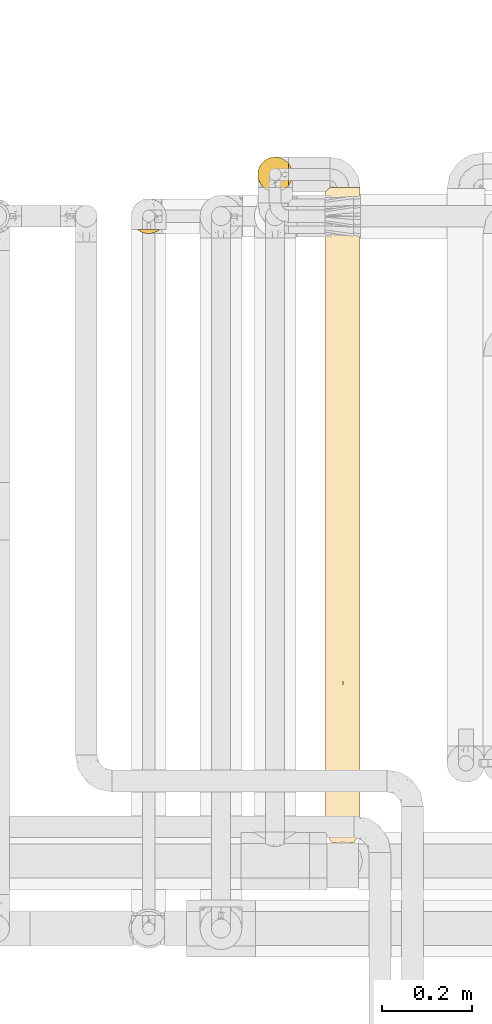
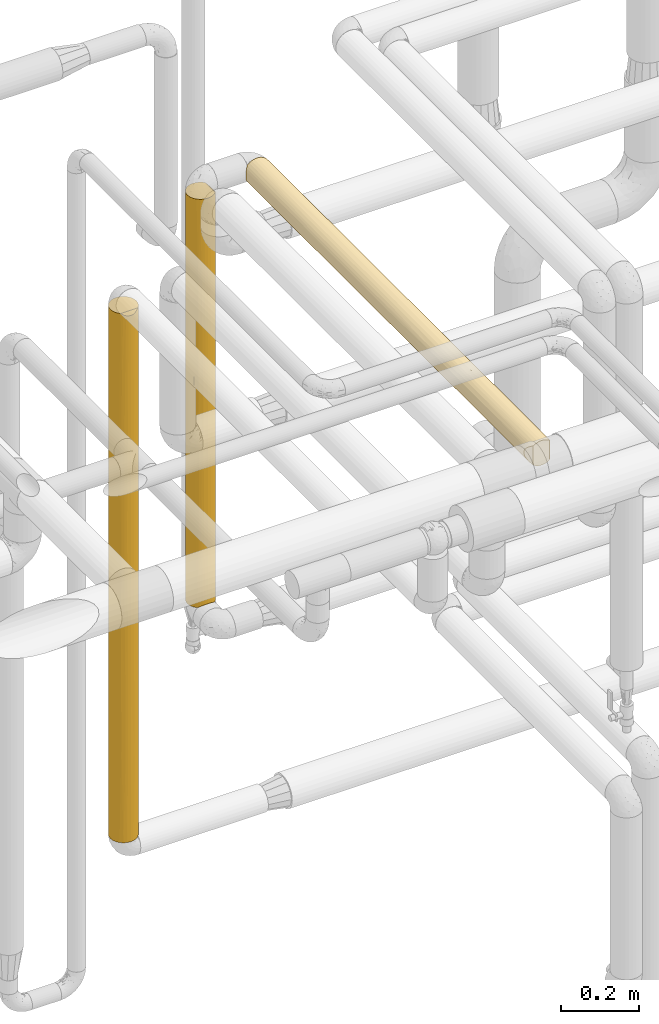
# One storey, part 46 of 827: 3 coverings.
"""IFC2X3 building model written with IfcOpenShell, lengths in millimetres."""

from ifc_helpers import new_model, entity, si_unit, converted_unit, derived_unit, direction, frame, origin, place, context, subcontext, project, spatial, faceted_brep, element, save


model = new_model("IFC2X3")

# Units and contexts
model_context = context("Model", 3, precision=0.01, world=origin(), true_north=direction((6.12303176911189e-17, 1.0)))
body_context = subcontext(model_context, "Body", "Model", "MODEL_VIEW")
ifc_project = project(units=[si_unit("LENGTHUNIT", "METRE", prefix="MILLI"), si_unit("AREAUNIT", "SQUARE_METRE"), si_unit("VOLUMEUNIT", "CUBIC_METRE"), converted_unit("PLANEANGLEUNIT", "DEGREE", entity("IfcRatioMeasure", 0.0174532925199433), si_unit("PLANEANGLEUNIT", "RADIAN"), dimensions=[0, 0, 0, 0, 0, 0, 0]), si_unit("MASSUNIT", "GRAM", prefix="KILO"), derived_unit("MASSDENSITYUNIT", [(si_unit("MASSUNIT", "GRAM", prefix="KILO"), 1), (si_unit("LENGTHUNIT", "METRE"), -3)]), derived_unit("MOMENTOFINERTIAUNIT", [(si_unit("LENGTHUNIT", "METRE"), 4)]), si_unit("TIMEUNIT", "SECOND"), si_unit("FREQUENCYUNIT", "HERTZ"), si_unit("THERMODYNAMICTEMPERATUREUNIT", "DEGREE_CELSIUS"), derived_unit("THERMALTRANSMITTANCEUNIT", [(si_unit("MASSUNIT", "GRAM", prefix="KILO"), 1), (si_unit("THERMODYNAMICTEMPERATUREUNIT", "KELVIN"), -1), (si_unit("TIMEUNIT", "SECOND"), -3)]), derived_unit("VOLUMETRICFLOWRATEUNIT", [(si_unit("LENGTHUNIT", "METRE"), 3), (si_unit("TIMEUNIT", "SECOND"), -1)]), derived_unit("MASSFLOWRATEUNIT", [(si_unit("MASSUNIT", "GRAM", prefix="KILO"), 1), (si_unit("TIMEUNIT", "SECOND"), -1)]), derived_unit("ROTATIONALFREQUENCYUNIT", [(si_unit("TIMEUNIT", "SECOND"), -1)]), si_unit("ELECTRICCURRENTUNIT", "AMPERE"), si_unit("ELECTRICVOLTAGEUNIT", "VOLT"), si_unit("POWERUNIT", "WATT"), si_unit("FORCEUNIT", "NEWTON", prefix="KILO"), si_unit("ILLUMINANCEUNIT", "LUX"), si_unit("LUMINOUSFLUXUNIT", "LUMEN"), si_unit("LUMINOUSINTENSITYUNIT", "CANDELA"), derived_unit("USERDEFINED", [(si_unit("MASSUNIT", "GRAM", prefix="KILO"), -1), (si_unit("LENGTHUNIT", "METRE"), -2), (si_unit("TIMEUNIT", "SECOND"), 3), (si_unit("LUMINOUSFLUXUNIT", "LUMEN"), 1)]), derived_unit("LINEARVELOCITYUNIT", [(si_unit("LENGTHUNIT", "METRE"), 1), (si_unit("TIMEUNIT", "SECOND"), -1)]), si_unit("PRESSUREUNIT", "PASCAL"), derived_unit("USERDEFINED", [(si_unit("LENGTHUNIT", "METRE"), -2), (si_unit("MASSUNIT", "GRAM", prefix="KILO"), 1), (si_unit("TIMEUNIT", "SECOND"), -2)]), derived_unit("LINEARFORCEUNIT", [(si_unit("MASSUNIT", "GRAM", prefix="KILO"), 1), (si_unit("LENGTHUNIT", "METRE"), 1), (si_unit("TIMEUNIT", "SECOND"), -2), (si_unit("LENGTHUNIT", "METRE"), -1)]), derived_unit("PLANARFORCEUNIT", [(si_unit("MASSUNIT", "GRAM", prefix="KILO"), 1), (si_unit("LENGTHUNIT", "METRE"), 1), (si_unit("TIMEUNIT", "SECOND"), -2), (si_unit("LENGTHUNIT", "METRE"), -2)])], contexts=[model_context])

# Site, building, storey
site_placement = place(None, origin())
site = spatial("IfcSite", under=ifc_project, at=site_placement, CompositionType="ELEMENT")
building_placement = place(site_placement, origin())
building = spatial("IfcBuilding", under=site, at=building_placement, CompositionType="ELEMENT")
storey_placement = place(building_placement, frame((0.0, 0.0, 28200.0)))
storey = spatial("IfcBuildingStorey", under=building, at=storey_placement, Name="08", CompositionType="ELEMENT", Elevation=28200.0)

# Coverings
covering_1_placement = place(storey_placement, frame((54299.79, 16110.78, 2660.04)))
element("IfcCovering", 1, at=covering_1_placement, inside=storey, Name=":ADSK_", ObjectType=":ADSK_", PredefinedType="INSULATION", context=body_context, shape_type="Brep", body=[
    faceted_brep([(23.02, 1.6, 5.55), (31.28, 1.6, 2.6), (40.0, 1.6, 1.6), (48.72, 1.6, 2.6), (56.97, 1.6, 5.55), (64.34, 1.6, 10.3), (64.34, 1.6, 69.69), (56.97, 1.6, 74.44), (48.72, 1.6, 77.39), (40.0, 1.6, 78.4), (31.28, 1.6, 77.39), (23.02, 1.6, 74.44), (15.65, 1.6, 69.69), (15.65, 1.6, 10.3), (59.2, 1452.5, 6.74), (49.93, 1452.5, 2.9), (40.0, 1452.5, 1.6), (31.8, 1452.5, 2.48), (23.99, 1452.5, 5.09), (16.92, 1452.5, 9.3), (10.91, 1452.5, 14.92), (10.88, 1452.5, 65.03), (16.89, 1452.5, 70.67), (23.97, 1452.5, 74.89), (31.79, 1452.5, 77.51), (40.0, 1452.5, 78.4), (49.93, 1452.5, 77.09), (59.2, 1452.5, 73.25), (67.15, 1452.5, 67.15), (73.25, 1452.5, 59.2), (77.09, 1452.5, 49.93), (78.4, 1452.5, 40.0), (77.09, 1452.5, 30.06), (73.25, 1452.5, 20.8), (67.15, 1452.5, 12.84), (2.98, 1173.83, 29.79), (2.2, 1443.8, 33.2), (4.0, 1445.59, 26.62), (6.08, 1209.09, 21.99), (5.44, 967.77, 23.25), (10.46, 1249.57, 15.46), (13.77, 1100.45, 11.95), (8.91, 1058.93, 17.44), (27.83, 1248.12, 3.57), (8.85, 810.39, 17.53), (11.55, 8.32, 14.2), (13.88, 340.69, 11.84), (2.57, 925.73, 31.39), (20.76, 1129.93, 6.76), (27.06, 442.82, 3.84), (27.06, 204.04, 3.84), (19.54, 214.27, 7.5), (2.94, 653.44, 29.93), (1.6, 457.43, 40.0), (1.6, 673.8, 40.0), (2.01, 24.0, 34.36), (1.6, 241.05, 40.0), (2.56, 303.36, 31.46), (6.8, 450.98, 20.69), (6.69, 226.01, 20.88), (8.07, 14.04, 18.65), (5.29, 18.62, 23.57), (1.6, 1226.82, 40.0), (1.6, 1443.2, 40.0), (40.0, 727.05, 1.6), (40.0, 545.68, 1.6), (40.0, 364.32, 1.6), (14.71, 534.08, 11.1), (20.63, 602.44, 6.84), (18.94, 412.01, 7.88), (40.0, 1089.77, 1.6), (40.0, 908.41, 1.6), (27.83, 1011.74, 3.57), (1.6, 890.17, 40.0), (20.81, 862.12, 6.73), (28.86, 725.52, 3.24), (3.25, 21.96, 28.84), (14.29, 729.46, 11.47), (6.93, 1448.52, 20.46), (5.21, 753.17, 23.72), (1.6, 24.68, 40.0), (65.7, 727.26, 11.47), (71.28, 881.11, 17.73), (70.83, 648.43, 17.11), (77.61, 1141.87, 32.29), (77.56, 909.84, 32.03), (75.47, 1022.08, 25.3), (63.37, 1158.85, 9.53), (59.53, 822.55, 6.93), (59.75, 581.75, 7.07), (48.39, 1185.88, 2.52), (54.69, 1006.28, 4.52), (46.7, 928.56, 2.19), (70.46, 1198.49, 16.62), (66.11, 340.49, 11.84), (59.46, 323.48, 6.9), (52.93, 204.08, 3.84), (51.95, 730.09, 3.5), (77.98, 24.0, 34.36), (78.4, 241.05, 40.0), (78.4, 24.68, 40.0), (73.3, 225.55, 20.88), (73.19, 450.09, 20.69), (64.72, 944.28, 10.61), (75.47, 1261.66, 25.3), (52.93, 442.89, 3.84), (76.74, 21.96, 28.84), (74.7, 18.62, 23.57), (55.96, 1239.91, 5.07), (77.05, 653.93, 29.92), (77.43, 303.36, 31.46), (71.92, 14.04, 18.65), (78.4, 457.43, 40.0), (68.44, 8.32, 14.2), (78.4, 890.17, 40.0), (67.1, 535.84, 12.8), (74.52, 746.35, 23.18), (78.4, 673.8, 40.0), (78.4, 1236.12, 40.0), (75.47, 1261.66, 54.69), (67.84, 969.35, 66.44), (65.7, 727.26, 68.52), (72.51, 754.88, 60.42), (77.61, 1141.87, 47.7), (48.48, 821.3, 77.45), (52.93, 442.89, 76.15), (56.41, 716.73, 74.71), (70.46, 1198.49, 63.37), (63.37, 1158.85, 70.46), (77.05, 653.93, 50.08), (75.47, 1022.08, 54.69), (46.72, 1231.25, 77.8), (40.0, 1089.77, 78.4), (66.11, 340.49, 68.15), (68.44, 8.32, 65.79), (73.3, 225.55, 59.11), (54.69, 1252.9, 75.47), (77.98, 24.0, 45.63), (77.43, 303.36, 48.53), (76.74, 21.96, 51.15), (71.92, 14.04, 61.34), (52.93, 204.08, 76.15), (40.0, 364.32, 78.4), (73.19, 450.09, 59.3), (60.45, 214.24, 72.49), (60.33, 451.94, 72.57), (74.7, 18.62, 56.42), (65.28, 532.86, 68.9), (54.69, 1006.28, 75.47), (40.0, 727.04, 78.4), (40.0, 545.68, 78.4), (77.56, 909.84, 47.96), (61.58, 917.33, 71.75), (72.16, 1011.5, 60.97), (46.8, 1023.31, 77.79), (27.81, 1248.05, 76.41), (6.91, 1448.53, 59.5), (6.07, 1208.66, 57.99), (10.42, 1249.33, 64.48), (20.63, 602.57, 73.15), (13.88, 340.69, 68.15), (20.53, 323.43, 73.1), (27.06, 442.82, 76.15), (27.06, 204.04, 76.15), (28.84, 725.46, 76.74), (27.81, 1011.5, 76.41), (20.8, 862.25, 73.25), (20.73, 1129.77, 73.21), (2.57, 926.1, 48.58), (2.94, 653.46, 50.07), (13.73, 1100.41, 68.01), (8.84, 809.04, 62.44), (14.29, 729.39, 68.52), (2.01, 24.0, 45.63), (11.09, 540.13, 65.28), (6.8, 450.95, 59.3), (6.69, 226.0, 59.11), (8.9, 1058.04, 62.52), (2.97, 1173.7, 50.18), (3.99, 1445.6, 53.35), (2.2, 1443.8, 46.78), (5.42, 967.2, 56.71), (3.25, 21.96, 51.15), (2.56, 303.36, 48.53), (5.29, 18.62, 56.42), (11.55, 8.32, 65.79), (8.07, 14.04, 61.34), (5.2, 753.19, 56.25)], [[[0, 1, 2, 3, 4, 5, 6, 7, 8, 9, 10, 11, 12, 13]], [[14, 15, 16, 17, 18, 19, 20, 21, 22, 23, 24, 25, 26, 27, 28, 29, 30, 31, 32, 33, 34]], [[35, 36, 37]], [[35, 38, 39]], [[40, 41, 42]], [[43, 18, 17]], [[39, 42, 44]], [[38, 42, 39]], [[13, 45, 46]], [[35, 39, 47]], [[18, 48, 19]], [[49, 50, 51]], [[52, 53, 54]], [[55, 56, 57]], [[52, 58, 57]], [[46, 45, 59]], [[59, 60, 61]], [[62, 63, 36]], [[19, 41, 40]], [[18, 43, 48]], [[49, 64, 65, 66, 50]], [[67, 68, 69]], [[57, 58, 59]], [[70, 17, 16]], [[1, 50, 66]], [[70, 71, 72, 43]], [[62, 47, 54, 73]], [[60, 59, 45]], [[51, 13, 46]], [[0, 50, 1]], [[41, 48, 74]], [[75, 49, 68]], [[59, 76, 57]], [[77, 41, 74]], [[52, 57, 53]], [[55, 57, 76]], [[44, 42, 41]], [[67, 58, 44]], [[78, 38, 37]], [[35, 47, 62]], [[62, 36, 35]], [[59, 61, 76]], [[46, 59, 58]], [[44, 79, 39]], [[70, 43, 17]], [[2, 1, 66]], [[48, 43, 72]], [[48, 72, 74]], [[19, 48, 41]], [[75, 74, 72]], [[68, 77, 74]], [[67, 69, 46]], [[64, 49, 75]], [[75, 68, 74]], [[49, 51, 69]], [[51, 50, 0]], [[13, 51, 0]], [[51, 46, 69]], [[79, 47, 39]], [[47, 52, 54]], [[37, 38, 35]], [[78, 20, 40]], [[38, 78, 40]], [[44, 41, 77]], [[67, 44, 77]], [[79, 58, 52]], [[38, 40, 42]], [[19, 40, 20]], [[58, 79, 44]], [[47, 79, 52]], [[71, 75, 72]], [[71, 64, 75]], [[49, 69, 68]], [[58, 67, 46]], [[68, 67, 77]], [[56, 55, 80]], [[56, 53, 57]], [[81, 82, 83]], [[84, 85, 86]], [[14, 34, 87]], [[88, 81, 89]], [[90, 91, 92]], [[34, 93, 87]], [[89, 94, 95]], [[95, 4, 96]], [[95, 5, 4]], [[97, 92, 91]], [[2, 66, 3]], [[98, 99, 100]], [[101, 94, 102]], [[88, 103, 81]], [[86, 104, 84]], [[66, 65, 105, 96]], [[101, 106, 107]], [[90, 108, 91]], [[109, 110, 102]], [[106, 101, 110]], [[107, 111, 101]], [[112, 110, 109]], [[3, 96, 4]], [[110, 98, 106]], [[94, 101, 113]], [[91, 108, 87]], [[113, 5, 94]], [[114, 85, 84]], [[110, 99, 98]], [[104, 33, 32]], [[91, 88, 97]], [[83, 115, 81]], [[101, 111, 113]], [[110, 101, 102]], [[83, 116, 102]], [[85, 117, 109]], [[34, 33, 93]], [[103, 88, 91]], [[32, 31, 118]], [[15, 90, 16]], [[104, 93, 33]], [[103, 82, 81]], [[66, 96, 3]], [[95, 96, 105]], [[89, 95, 105]], [[95, 94, 5]], [[89, 105, 97]], [[89, 81, 115]], [[116, 83, 82]], [[92, 64, 71, 70]], [[97, 88, 89]], [[103, 91, 87]], [[87, 93, 103]], [[82, 93, 86]], [[93, 82, 103]], [[85, 116, 86]], [[64, 92, 97]], [[90, 92, 70]], [[16, 90, 70]], [[108, 15, 14]], [[15, 108, 90]], [[87, 108, 14]], [[84, 32, 118]], [[93, 104, 86]], [[32, 84, 104]], [[114, 84, 118]], [[116, 85, 109]], [[65, 97, 105]], [[65, 64, 97]], [[115, 102, 94]], [[86, 116, 82]], [[102, 116, 109]], [[102, 115, 83]], [[89, 115, 94]], [[110, 112, 99]], [[117, 85, 114]], [[117, 112, 109]], [[119, 30, 29]], [[120, 121, 122]], [[30, 119, 123]], [[124, 125, 126]], [[127, 28, 128]], [[29, 28, 127]], [[30, 118, 31]], [[122, 129, 130]], [[131, 25, 132]], [[133, 134, 135]], [[128, 27, 136]], [[137, 99, 138]], [[138, 139, 137]], [[129, 112, 117]], [[140, 135, 134]], [[8, 141, 142]], [[135, 139, 138]], [[138, 143, 135]], [[125, 144, 145]], [[125, 141, 144]], [[27, 26, 136]], [[135, 140, 146]], [[144, 6, 133]], [[28, 27, 128]], [[125, 145, 126]], [[147, 143, 122]], [[141, 8, 7]], [[143, 138, 129]], [[129, 138, 112]], [[6, 134, 133]], [[148, 136, 131]], [[125, 149, 150, 142, 141]], [[135, 146, 139]], [[133, 135, 143]], [[151, 117, 114]], [[151, 114, 123]], [[121, 120, 152]], [[9, 8, 142]], [[120, 153, 127]], [[120, 127, 128]], [[154, 149, 124]], [[118, 123, 114]], [[127, 153, 119]], [[144, 141, 7]], [[6, 144, 7]], [[144, 133, 145]], [[133, 147, 145]], [[121, 152, 126]], [[126, 145, 147]], [[124, 126, 148]], [[148, 131, 154]], [[125, 124, 149]], [[152, 128, 148]], [[147, 122, 121]], [[129, 122, 143]], [[153, 122, 130]], [[128, 152, 120]], [[126, 152, 148]], [[131, 136, 26]], [[128, 136, 148]], [[25, 131, 26]], [[131, 132, 154]], [[149, 154, 132]], [[148, 154, 124]], [[127, 119, 29]], [[123, 119, 130]], [[123, 130, 151]], [[30, 123, 118]], [[130, 129, 151]], [[151, 129, 117]], [[143, 147, 133]], [[126, 147, 121]], [[122, 153, 120]], [[119, 153, 130]], [[99, 137, 100]], [[99, 112, 138]], [[155, 132, 24]], [[156, 157, 158]], [[159, 160, 161]], [[142, 150, 162, 163]], [[164, 165, 166]], [[155, 167, 165]], [[168, 54, 169]], [[155, 24, 23]], [[9, 142, 10]], [[170, 171, 172]], [[173, 56, 80]], [[174, 175, 160]], [[160, 175, 176]], [[161, 12, 11]], [[157, 177, 158]], [[166, 167, 170]], [[62, 168, 178]], [[179, 180, 178]], [[157, 178, 181]], [[165, 149, 132, 155]], [[182, 176, 183]], [[11, 163, 161]], [[176, 182, 184]], [[160, 176, 185]], [[183, 169, 53]], [[160, 185, 12]], [[10, 163, 11]], [[173, 183, 56]], [[186, 176, 184]], [[158, 22, 21]], [[171, 170, 177]], [[178, 157, 179]], [[165, 167, 166]], [[183, 173, 182]], [[169, 183, 175]], [[22, 170, 167]], [[180, 63, 62]], [[180, 62, 178]], [[168, 62, 73, 54]], [[176, 186, 185]], [[183, 176, 175]], [[187, 175, 171]], [[25, 24, 132]], [[168, 181, 178]], [[23, 22, 167]], [[167, 155, 23]], [[166, 170, 172]], [[172, 159, 166]], [[166, 159, 164]], [[159, 174, 160]], [[149, 165, 164]], [[159, 172, 174]], [[164, 159, 162]], [[142, 163, 10]], [[161, 163, 162]], [[159, 161, 162]], [[161, 160, 12]], [[187, 168, 169]], [[177, 157, 181]], [[179, 157, 156]], [[177, 181, 171]], [[158, 177, 170]], [[187, 171, 181]], [[174, 171, 175]], [[22, 158, 170]], [[158, 21, 156]], [[168, 187, 181]], [[175, 187, 169]], [[150, 164, 162]], [[150, 149, 164]], [[171, 174, 172]], [[183, 53, 56]], [[54, 53, 169]], [[134, 6, 5, 113, 111, 107, 106, 98, 100, 137, 139, 146, 140]], [[173, 80, 55, 76, 61, 60, 45, 13, 12, 185, 186, 184, 182]], [[36, 63, 180, 179, 156, 21, 20, 78, 37]]]),
])
covering_2_placement = place(storey_placement, frame((54149.79, 17552.38, 1397.5)))
element("IfcCovering", 2, at=covering_2_placement, inside=storey, Name=":ADSK_", ObjectType=":ADSK_", PredefinedType="INSULATION", context=body_context, shape_type="Brep", body=[
    faceted_brep([(56.01, 5.09, 1273.4), (63.08, 9.31, 1273.4), (69.1, 14.94, 1273.4), (69.1, 65.05, 1273.4), (63.08, 70.68, 1273.4), (56.01, 74.9, 1273.4), (48.2, 77.51, 1273.4), (40.0, 78.4, 1273.4), (30.06, 77.09, 1273.4), (20.8, 73.25, 1273.4), (12.84, 67.15, 1273.4), (6.74, 59.2, 1273.4), (2.9, 49.93, 1273.4), (1.6, 40.0, 1273.4), (2.9, 30.06, 1273.4), (6.74, 20.8, 1273.4), (12.84, 12.84, 1273.4), (20.8, 6.74, 1273.4), (30.06, 2.9, 1273.4), (40.0, 1.6, 1273.4), (48.2, 2.48, 1273.4), (77.09, 49.93, 1.6), (78.4, 40.0, 1.6), (77.51, 31.79, 1.6), (74.9, 23.98, 1.6), (70.68, 16.91, 1.6), (65.05, 10.9, 1.6), (14.94, 10.9, 1.6), (9.31, 16.91, 1.6), (5.09, 23.98, 1.6), (2.48, 31.79, 1.6), (1.6, 40.0, 1.6), (2.9, 49.93, 1.6), (6.74, 59.2, 1.6), (12.84, 67.15, 1.6), (20.8, 73.25, 1.6), (30.06, 77.09, 1.6), (40.0, 78.4, 1.6), (49.93, 77.09, 1.6), (59.2, 73.25, 1.6), (67.15, 67.15, 1.6), (73.25, 59.2, 1.6), (59.51, 6.92, 5.57), (62.54, 8.91, 299.92), (76.41, 27.82, 357.21), (70.45, 16.6, 321.3), (77.02, 29.8, 1005.37), (74.47, 23.08, 1069.54), (76.5, 28.07, 732.1), (47.71, 2.38, 671.05), (56.75, 5.44, 544.14), (59.66, 7.01, 912.24), (50.2, 2.98, 305.85), (56.59, 5.37, 205.09), (40.0, 1.6, 227.27), (46.78, 2.2, 10.29), (53.36, 4.0, 8.5), (65.76, 11.52, 1049.24), (66.56, 12.27, 805.85), (40.0, 1.6, 1057.02), (50.05, 2.93, 966.7), (70.94, 17.26, 640.31), (73.07, 20.48, 1269.42), (71.08, 17.45, 963.52), (40.0, 1.6, 957.78), (40.0, 1.6, 876.39), (78.4, 40.0, 632.85), (78.4, 40.0, 831.35), (40.0, 1.6, 10.9), (78.4, 40.0, 317.22), (64.71, 10.6, 562.87), (77.79, 33.21, 1264.7), (76.0, 26.63, 1266.5), (78.4, 40.0, 1047.72), (78.4, 40.0, 1264.1), (40.0, 1.6, 660.01), (40.0, 1.6, 642.15), (40.0, 1.6, 443.64), (78.4, 40.0, 217.97), (78.4, 40.0, 398.6), (78.4, 40.0, 614.98), (63.37, 70.46, 282.77), (70.46, 63.37, 254.12), (61.81, 71.6, 549.57), (65.92, 68.32, 733.64), (70.94, 62.73, 634.54), (77.7, 47.26, 308.29), (73.07, 59.51, 1269.42), (71.29, 62.25, 1059.46), (74.59, 56.66, 925.92), (75.47, 54.69, 357.63), (77.52, 48.15, 939.54), (77.49, 48.3, 616.5), (53.64, 75.89, 191.55), (71.08, 62.54, 847.06), (76.0, 53.36, 1266.5), (47.5, 77.65, 312.94), (40.0, 78.4, 624.28), (50.65, 76.89, 692.04), (54.69, 75.47, 409.71), (40.0, 78.4, 217.97), (40.0, 78.4, 407.9), (77.79, 46.78, 1264.7), (66.24, 68.03, 996.73), (52.17, 76.41, 996.74), (40.0, 78.4, 1057.02), (59.66, 72.98, 1058.41), (59.66, 72.98, 812.0), (74.94, 55.9, 587.7), (40.0, 78.4, 840.65), (16.62, 70.46, 260.79), (9.53, 63.37, 325.87), (32.89, 77.73, 948.84), (31.63, 77.47, 628.43), (25.3, 75.47, 905.95), (25.3, 75.47, 369.04), (32.73, 77.7, 312.94), (1.6, 40.0, 217.97), (1.6, 40.0, 1070.24), (23.73, 74.78, 606.15), (2.3, 47.31, 952.13), (4.52, 54.69, 246.65), (9.28, 63.04, 615.91), (4.52, 54.69, 531.31), (2.29, 47.28, 326.15), (9.53, 63.37, 905.95), (4.52, 54.69, 1004.02), (16.62, 70.46, 1004.02), (16.62, 70.46, 637.5), (2.22, 46.88, 563.24), (3.47, 51.84, 767.67), (1.6, 40.0, 434.34), (1.6, 40.0, 650.71), (1.6, 40.0, 867.09), (1.6, 40.0, 1057.02), (3.1, 29.34, 582.95), (3.58, 27.82, 278.25), (7.01, 20.33, 462.99), (17.26, 9.05, 640.45), (23.65, 5.25, 374.73), (28.04, 3.5, 542.89), (9.53, 16.62, 992.22), (2.34, 32.49, 962.05), (4.1, 26.35, 1083.44), (6.59, 21.05, 248.52), (10.84, 15.01, 282.23), (4.52, 25.3, 865.28), (8.39, 18.18, 725.42), (17.44, 8.91, 314.42), (11.67, 14.07, 541.35), (29.8, 2.97, 269.71), (26.63, 4.0, 8.5), (20.48, 6.92, 5.57), (32.94, 2.25, 799.96), (16.62, 9.53, 1020.87), (33.21, 2.2, 10.29), (25.3, 4.52, 917.65), (32.18, 2.4, 1040.19)], [[[0, 1, 2, 3, 4, 5, 6, 7, 8, 9, 10, 11, 12, 13, 14, 15, 16, 17, 18, 19, 20]], [[21, 22, 23, 24, 25, 26, 27, 28, 29, 30, 31, 32, 33, 34, 35, 36, 37, 38, 39, 40, 41]], [[42, 26, 43]], [[24, 23, 44]], [[43, 26, 45]], [[46, 47, 48]], [[49, 50, 51]], [[50, 52, 53]], [[54, 55, 52]], [[52, 56, 53]], [[57, 51, 58]], [[59, 60, 20]], [[44, 61, 45]], [[62, 63, 47]], [[60, 59, 64, 65]], [[66, 67, 48]], [[60, 49, 51]], [[54, 68, 55]], [[23, 69, 44]], [[50, 70, 51]], [[70, 61, 58]], [[70, 50, 43]], [[20, 60, 0]], [[46, 71, 72]], [[56, 52, 55]], [[62, 2, 63]], [[53, 42, 43]], [[48, 44, 66]], [[73, 71, 46]], [[45, 24, 44]], [[73, 74, 71]], [[48, 63, 61]], [[45, 26, 25]], [[1, 0, 51]], [[49, 52, 50]], [[57, 2, 1]], [[48, 47, 63]], [[61, 44, 48]], [[72, 62, 47]], [[67, 46, 48]], [[20, 19, 59]], [[60, 65, 49]], [[60, 51, 0]], [[49, 65, 75, 76, 77]], [[52, 49, 77]], [[45, 70, 43]], [[61, 63, 58]], [[57, 58, 63]], [[51, 70, 58]], [[2, 57, 63]], [[51, 57, 1]], [[45, 25, 24]], [[70, 45, 61]], [[42, 53, 56]], [[50, 53, 43]], [[52, 77, 54]], [[23, 22, 78, 69]], [[44, 69, 79, 80, 66]], [[72, 47, 46]], [[46, 67, 73]], [[40, 81, 82]], [[83, 84, 85]], [[86, 79, 69, 78]], [[21, 78, 22]], [[3, 87, 88]], [[87, 89, 88]], [[41, 90, 21]], [[89, 91, 92]], [[93, 81, 39]], [[91, 73, 67]], [[41, 40, 82]], [[88, 89, 94]], [[95, 89, 87]], [[96, 93, 38]], [[96, 97, 98]], [[99, 83, 81]], [[86, 92, 79]], [[96, 100, 101, 97]], [[73, 91, 102]], [[3, 103, 4]], [[39, 81, 40]], [[5, 104, 6]], [[105, 6, 104]], [[106, 4, 103]], [[106, 5, 4]], [[95, 102, 91]], [[106, 107, 104]], [[108, 89, 92]], [[98, 104, 107]], [[107, 83, 98]], [[105, 7, 6]], [[102, 74, 73]], [[92, 91, 67]], [[91, 89, 95]], [[92, 67, 66, 80, 79]], [[92, 90, 108]], [[99, 98, 83]], [[82, 85, 90]], [[98, 99, 96]], [[109, 104, 98]], [[85, 82, 81]], [[90, 41, 82]], [[38, 37, 100]], [[93, 96, 99]], [[38, 100, 96]], [[81, 93, 99]], [[39, 38, 93]], [[84, 83, 107]], [[85, 81, 83]], [[107, 103, 84]], [[94, 103, 88]], [[86, 21, 90]], [[21, 86, 78]], [[92, 86, 90]], [[107, 106, 103]], [[5, 106, 104]], [[89, 108, 94]], [[3, 88, 103]], [[85, 84, 94]], [[103, 94, 84]], [[104, 109, 105]], [[90, 85, 108]], [[108, 85, 94]], [[97, 109, 98]], [[110, 34, 111]], [[112, 113, 114]], [[8, 105, 112]], [[8, 114, 9]], [[36, 35, 115]], [[116, 101, 100]], [[32, 31, 117]], [[118, 13, 12]], [[116, 113, 101]], [[114, 113, 119]], [[120, 118, 12]], [[33, 121, 111]], [[122, 111, 123]], [[121, 124, 123]], [[36, 100, 37]], [[8, 7, 105]], [[109, 112, 105]], [[125, 126, 11]], [[127, 10, 9]], [[33, 32, 121]], [[33, 111, 34]], [[114, 127, 9]], [[125, 11, 10]], [[12, 11, 126]], [[125, 127, 128]], [[128, 110, 111]], [[122, 128, 111]], [[129, 130, 123]], [[34, 110, 35]], [[123, 124, 129]], [[110, 128, 115]], [[125, 122, 130]], [[120, 126, 130]], [[128, 127, 114]], [[125, 10, 127]], [[115, 35, 110]], [[117, 124, 32]], [[111, 121, 123]], [[124, 117, 131]], [[124, 131, 129]], [[32, 124, 121]], [[130, 132, 133]], [[133, 120, 130]], [[129, 132, 130]], [[125, 130, 126]], [[129, 131, 132]], [[12, 126, 120]], [[120, 133, 134, 118]], [[113, 112, 109]], [[8, 112, 114]], [[113, 109, 97, 101]], [[113, 115, 119]], [[116, 36, 115]], [[36, 116, 100]], [[113, 116, 115]], [[130, 122, 123]], [[128, 122, 125]], [[115, 128, 119]], [[114, 119, 128]], [[135, 136, 137]], [[138, 139, 140]], [[15, 141, 16]], [[142, 134, 133, 132]], [[142, 132, 135]], [[142, 143, 14]], [[117, 30, 136]], [[137, 144, 145]], [[145, 144, 28]], [[141, 146, 147]], [[148, 145, 27]], [[148, 149, 145]], [[139, 150, 140]], [[151, 139, 152]], [[143, 141, 15]], [[153, 76, 75, 65, 64]], [[17, 16, 154]], [[140, 150, 77]], [[150, 151, 155]], [[155, 54, 150]], [[156, 138, 140]], [[148, 139, 138]], [[17, 156, 18]], [[140, 77, 76]], [[153, 157, 156]], [[151, 150, 139]], [[152, 148, 27]], [[149, 138, 147]], [[29, 136, 30]], [[16, 141, 154]], [[135, 146, 142]], [[137, 147, 135]], [[117, 31, 30]], [[146, 135, 147]], [[154, 138, 156]], [[153, 140, 76]], [[18, 157, 19]], [[131, 136, 135]], [[138, 154, 141]], [[156, 17, 154]], [[14, 13, 118, 134]], [[143, 142, 146]], [[14, 134, 142]], [[141, 143, 146]], [[15, 14, 143]], [[149, 147, 137]], [[138, 141, 147]], [[145, 149, 137]], [[148, 138, 149]], [[144, 137, 136]], [[27, 145, 28]], [[136, 29, 144]], [[28, 144, 29]], [[157, 153, 64]], [[140, 153, 156]], [[157, 64, 59, 19]], [[18, 156, 157]], [[54, 155, 68]], [[54, 77, 150]], [[152, 139, 148]], [[136, 131, 117]], [[132, 131, 135]], [[2, 62, 72, 71, 74, 102, 95, 87, 3]], [[56, 55, 68, 155, 151, 152, 27, 26, 42]]]),
])
covering_3_placement = place(storey_placement, frame((53869.79, 17460.0, 820.0)))
element("IfcCovering", 3, at=covering_3_placement, inside=storey, Name=":ADSK_", ObjectType=":ADSK_", PredefinedType="INSULATION", context=body_context, shape_type="Brep", body=[
    faceted_brep([(6.74, 20.8, 1.6), (2.9, 30.06, 1.6), (1.6, 40.0, 1.6), (2.9, 49.93, 1.6), (6.74, 59.2, 1.6), (12.84, 67.15, 1.6), (20.8, 73.25, 1.6), (30.06, 77.09, 1.6), (40.0, 78.4, 1.6), (48.2, 77.51, 1.6), (56.01, 74.9, 1.6), (63.08, 70.68, 1.6), (69.1, 65.05, 1.6), (69.1, 14.94, 1.6), (63.08, 9.31, 1.6), (56.01, 5.09, 1.6), (48.2, 2.48, 1.6), (40.0, 1.6, 1.6), (30.06, 2.9, 1.6), (20.8, 6.74, 1.6), (12.84, 12.84, 1.6), (1.6, 40.0, 1649.06), (2.48, 31.79, 1649.06), (5.09, 23.98, 1649.06), (9.31, 16.91, 1649.06), (14.94, 10.9, 1649.06), (65.05, 10.9, 1649.06), (70.68, 16.91, 1649.06), (74.9, 23.98, 1649.06), (77.51, 31.79, 1649.06), (78.4, 40.0, 1649.06), (77.09, 49.93, 1649.06), (73.25, 59.2, 1649.06), (67.15, 67.15, 1649.06), (59.2, 73.25, 1649.06), (49.93, 77.09, 1649.06), (40.0, 78.4, 1649.06), (30.06, 77.09, 1649.06), (20.8, 73.25, 1649.06), (12.84, 67.15, 1649.06), (6.74, 59.2, 1649.06), (2.9, 49.93, 1649.06), (40.0, 1.6, 1207.02), (31.75, 2.49, 1315.21), (29.53, 3.05, 962.59), (16.78, 9.41, 1243.8), (17.51, 8.86, 1456.6), (11.96, 13.75, 1363.42), (7.01, 20.33, 1432.0), (7.01, 20.33, 1165.48), (20.48, 6.92, 1645.09), (26.63, 4.0, 1642.16), (3.58, 27.82, 1363.43), (1.6, 40.0, 1432.69), (1.6, 40.0, 1258.08), (1.6, 40.0, 1216.32), (33.21, 2.2, 1640.37), (16.62, 9.53, 312.03), (40.0, 1.6, 217.97), (25.3, 4.52, 494.85), (15.38, 10.52, 656.23), (1.6, 40.0, 434.34), (2.25, 32.96, 326.15), (3.25, 28.83, 501.35), (4.52, 25.3, 317.05), (23.31, 5.41, 1265.67), (12.26, 13.43, 1106.52), (25.3, 4.52, 226.95), (32.56, 2.32, 302.95), (31.56, 2.53, 677.69), (40.0, 1.6, 774.27), (8.83, 17.56, 839.12), (3.9, 26.89, 706.79), (5.83, 22.47, 555.69), (9.53, 16.62, 234.22), (40.0, 1.6, 1423.39), (40.0, 1.6, 1639.76), (1.6, 40.0, 783.57), (1.6, 40.0, 650.71), (2.85, 30.25, 1033.84), (1.6, 40.0, 217.97), (22.88, 5.62, 1044.6), (23.16, 5.48, 754.72), (9.53, 16.62, 508.26), (40.0, 1.6, 387.93), (40.0, 1.6, 434.34), (40.0, 1.6, 581.1), (1.6, 40.0, 1062.58), (1.6, 40.0, 999.95), (1.6, 40.0, 867.09), (5.43, 23.27, 960.13), (40.0, 1.6, 990.65), (17.22, 9.08, 933.47), (9.53, 63.37, 1389.87), (16.62, 70.46, 1324.79), (2.41, 47.87, 650.71), (2.55, 48.5, 964.83), (2.29, 47.28, 326.15), (4.52, 54.69, 1422.23), (4.52, 54.69, 1153.09), (2.32, 47.42, 1345.38), (40.0, 78.4, 1432.69), (40.0, 78.4, 217.97), (5.59, 57.04, 891.48), (32.58, 77.67, 305.28), (25.3, 75.47, 499.91), (32.62, 77.68, 527.61), (9.53, 63.37, 258.53), (16.62, 70.46, 313.91), (17.75, 71.29, 1074.83), (11.24, 65.45, 1057.56), (25.3, 75.47, 1404.01), (32.71, 77.7, 1324.51), (25.3, 75.47, 1119.35), (18.66, 71.92, 816.01), (9.53, 63.37, 725.25), (25.3, 75.47, 229.7), (3.89, 53.07, 196.25), (40.0, 78.4, 392.58), (27.93, 76.45, 831.89), (14.26, 68.5, 559.4), (8.49, 61.95, 491.89), (33.12, 77.77, 1087.42), (4.52, 54.69, 406.92), (5.32, 56.49, 646.18), (40.0, 78.4, 1216.32), (40.0, 78.4, 999.95), (40.0, 78.4, 867.09), (40.0, 78.4, 783.57), (40.0, 78.4, 650.71), (40.0, 78.4, 588.08), (40.0, 78.4, 434.34), (63.37, 70.46, 1416.44), (54.69, 75.47, 1333.61), (70.58, 63.21, 406.86), (66.24, 68.03, 287.24), (66.56, 67.73, 544.14), (75.47, 54.69, 1423.71), (77.67, 47.43, 1347.71), (75.47, 54.69, 1155.81), (77.46, 48.43, 972.97), (70.46, 63.37, 1338.63), (77.5, 48.24, 335.45), (76.0, 53.36, 8.5), (74.58, 56.68, 384.99), (52.17, 76.41, 287.23), (59.66, 72.98, 485.18), (47.03, 77.75, 1324.51), (59.66, 72.98, 218.66), (51.16, 76.74, 1149.31), (62.43, 71.16, 811.54), (53.1, 76.09, 943.87), (57.52, 74.16, 1094.97), (78.4, 40.0, 876.39), (76.94, 50.46, 688.07), (77.79, 46.78, 10.29), (78.4, 40.0, 227.27), (78.4, 40.0, 10.9), (71.13, 62.48, 194.06), (78.4, 40.0, 1432.69), (78.4, 40.0, 443.64), (73.07, 59.51, 5.57), (49.74, 77.14, 616.82), (69.47, 64.61, 994.43), (74.37, 57.11, 606.06), (74.51, 56.83, 895.94), (63.37, 70.46, 1142.4), (78.4, 40.0, 1262.73), (78.4, 40.0, 1216.32), (78.4, 40.0, 1069.55), (56.72, 74.56, 690.53), (78.4, 40.0, 660.02), (70.91, 62.77, 717.19), (76.41, 27.82, 1371.13), (52.17, 3.58, 287.23), (49.89, 2.89, 611.39), (72.98, 20.33, 1184.48), (72.95, 20.28, 1431.53), (77.07, 30.01, 1042.43), (53.36, 4.0, 1642.16), (50.2, 2.98, 1333.18), (56.65, 5.39, 1277.02), (62.55, 8.91, 1334.51), (68.71, 14.5, 1306.51), (59.66, 7.01, 218.66), (46.78, 2.2, 1640.37), (77.5, 31.75, 335.45), (77.79, 33.21, 10.29), (59.51, 6.92, 1645.09), (76.0, 26.63, 8.5), (74.58, 23.31, 384.99), (73.07, 20.48, 5.57), (76.94, 29.53, 688.07), (66.43, 12.14, 1023.7), (49.77, 2.86, 1114.01), (49.55, 2.8, 894.57), (59.66, 7.01, 485.18), (66.24, 11.96, 287.24), (57.86, 6.0, 775.99), (64.8, 10.68, 673.81), (56.77, 5.45, 1070.68), (74.05, 22.24, 923.83), (68.81, 14.61, 499.88), (71.04, 17.39, 315.6), (74.37, 22.88, 606.06), (70.91, 17.22, 717.19)], [[[0, 1, 2, 3, 4, 5, 6, 7, 8, 9, 10, 11, 12, 13, 14, 15, 16, 17, 18, 19, 20]], [[21, 22, 23, 24, 25, 26, 27, 28, 29, 30, 31, 32, 33, 34, 35, 36, 37, 38, 39, 40, 41]], [[42, 43, 44]], [[45, 46, 47]], [[24, 48, 47]], [[49, 47, 48]], [[24, 47, 25]], [[50, 46, 51]], [[52, 53, 54, 55]], [[56, 51, 43]], [[19, 57, 20]], [[52, 48, 23]], [[18, 17, 58]], [[52, 23, 22]], [[57, 59, 60]], [[61, 62, 63]], [[62, 1, 64]], [[43, 51, 65]], [[66, 47, 49]], [[67, 68, 59]], [[69, 59, 68]], [[64, 1, 0]], [[70, 44, 69]], [[18, 67, 19]], [[71, 72, 73]], [[45, 47, 66]], [[20, 74, 0]], [[75, 76, 56]], [[63, 77, 78, 61]], [[19, 67, 57]], [[0, 74, 64]], [[79, 77, 72]], [[42, 75, 43]], [[46, 50, 25]], [[52, 22, 53]], [[79, 52, 55]], [[73, 72, 63]], [[1, 80, 2]], [[56, 43, 75]], [[43, 65, 44]], [[65, 81, 44]], [[69, 82, 59]], [[59, 82, 60]], [[74, 57, 83]], [[71, 83, 60]], [[68, 58, 84, 85, 86]], [[79, 49, 52]], [[79, 55, 87, 88, 89, 77]], [[90, 72, 71]], [[22, 21, 53]], [[57, 74, 20]], [[64, 74, 83]], [[58, 68, 18]], [[57, 67, 59]], [[69, 86, 70]], [[18, 68, 67]], [[86, 69, 68]], [[91, 42, 44, 70]], [[44, 81, 82]], [[44, 82, 69]], [[82, 92, 60]], [[92, 66, 71]], [[57, 60, 83]], [[92, 71, 60]], [[79, 90, 49]], [[1, 62, 80]], [[61, 80, 62]], [[63, 62, 64]], [[73, 64, 83]], [[63, 72, 77]], [[64, 73, 63]], [[71, 73, 83]], [[71, 66, 49]], [[92, 81, 45]], [[92, 45, 66]], [[65, 51, 46]], [[47, 46, 25]], [[65, 46, 45]], [[23, 48, 24]], [[49, 48, 52]], [[45, 81, 65]], [[82, 81, 92]], [[72, 90, 79]], [[71, 49, 90]], [[93, 39, 94]], [[95, 89, 96]], [[61, 97, 80]], [[94, 39, 38]], [[98, 41, 40]], [[99, 96, 100]], [[37, 36, 101]], [[7, 102, 8]], [[99, 103, 96]], [[3, 80, 97]], [[104, 105, 106]], [[107, 108, 5]], [[109, 110, 94]], [[111, 112, 113]], [[95, 61, 78, 77, 89]], [[114, 115, 110]], [[7, 6, 116]], [[117, 3, 97]], [[38, 37, 111]], [[93, 110, 99]], [[104, 118, 102]], [[108, 105, 116]], [[119, 114, 113]], [[108, 6, 5]], [[54, 53, 100, 87, 55]], [[120, 107, 121]], [[111, 94, 38]], [[113, 112, 122]], [[39, 93, 40]], [[5, 4, 107]], [[107, 120, 108]], [[110, 93, 94]], [[41, 53, 21]], [[3, 2, 80]], [[98, 93, 99]], [[109, 94, 113]], [[110, 115, 103]], [[113, 122, 119]], [[120, 105, 108]], [[117, 107, 4]], [[123, 124, 121]], [[101, 112, 37]], [[94, 111, 113]], [[108, 116, 6]], [[104, 7, 116]], [[93, 98, 40]], [[100, 41, 98]], [[87, 100, 96]], [[41, 100, 53]], [[99, 100, 98]], [[96, 89, 88, 87]], [[124, 95, 103]], [[95, 96, 103]], [[97, 95, 123]], [[110, 103, 99]], [[103, 115, 124]], [[112, 101, 125]], [[112, 125, 122]], [[37, 112, 111]], [[119, 126, 127, 128]], [[121, 124, 115]], [[122, 126, 119]], [[105, 114, 119]], [[106, 119, 128]], [[7, 104, 102]], [[105, 104, 116]], [[106, 128, 129, 130, 131, 118]], [[104, 106, 118]], [[95, 124, 123]], [[121, 115, 120]], [[123, 121, 107]], [[115, 114, 120]], [[105, 120, 114]], [[122, 125, 126]], [[95, 97, 61]], [[97, 123, 117]], [[107, 117, 123]], [[4, 3, 117]], [[113, 114, 109]], [[114, 110, 109]], [[119, 106, 105]], [[33, 132, 34]], [[34, 132, 133]], [[134, 135, 136]], [[137, 138, 139]], [[140, 139, 138]], [[32, 137, 141]], [[142, 143, 144]], [[133, 35, 34]], [[145, 102, 118, 131]], [[136, 135, 146]], [[147, 35, 133]], [[146, 135, 148]], [[32, 31, 137]], [[125, 147, 149]], [[145, 148, 10]], [[150, 151, 152]], [[153, 154, 140]], [[155, 143, 142]], [[156, 157, 155]], [[134, 158, 135]], [[31, 30, 159]], [[11, 148, 135]], [[142, 154, 160]], [[11, 135, 12]], [[158, 143, 161]], [[32, 141, 33]], [[162, 127, 151]], [[163, 141, 139]], [[149, 127, 126, 125]], [[145, 10, 9]], [[160, 156, 142]], [[158, 161, 12]], [[145, 9, 102]], [[162, 145, 131]], [[152, 151, 149]], [[35, 101, 36]], [[155, 142, 156]], [[142, 144, 154]], [[144, 164, 154]], [[140, 165, 139]], [[139, 165, 163]], [[132, 141, 166]], [[150, 166, 163]], [[138, 159, 167, 168, 169]], [[162, 146, 145]], [[162, 131, 130, 129, 128, 127]], [[170, 151, 150]], [[9, 8, 102]], [[141, 132, 33]], [[133, 132, 166]], [[159, 138, 31]], [[141, 137, 139]], [[140, 169, 153]], [[31, 138, 137]], [[169, 140, 138]], [[171, 160, 154, 153]], [[154, 164, 165]], [[154, 165, 140]], [[165, 172, 163]], [[172, 136, 150]], [[141, 163, 166]], [[172, 150, 163]], [[162, 170, 146]], [[35, 147, 101]], [[125, 101, 147]], [[149, 147, 133]], [[152, 133, 166]], [[149, 151, 127]], [[133, 152, 149]], [[150, 152, 166]], [[150, 136, 146]], [[172, 164, 134]], [[172, 134, 136]], [[144, 143, 158]], [[135, 158, 12]], [[144, 158, 134]], [[10, 148, 11]], [[146, 148, 145]], [[134, 164, 144]], [[165, 164, 172]], [[151, 170, 162]], [[150, 146, 170]], [[173, 29, 28]], [[174, 175, 85]], [[176, 173, 177]], [[27, 177, 28]], [[173, 178, 168]], [[179, 180, 181]], [[182, 183, 26]], [[184, 15, 14]], [[174, 58, 16]], [[185, 75, 180]], [[156, 186, 187]], [[188, 181, 182]], [[189, 190, 191]], [[186, 192, 190]], [[186, 156, 160]], [[183, 176, 177]], [[179, 181, 188]], [[26, 188, 182]], [[174, 16, 15]], [[29, 173, 159]], [[183, 193, 176]], [[180, 179, 185]], [[194, 91, 195]], [[184, 196, 174]], [[13, 197, 14]], [[14, 197, 184]], [[198, 195, 175]], [[199, 193, 198]], [[193, 182, 200]], [[192, 178, 201]], [[189, 187, 186]], [[202, 203, 190]], [[201, 204, 192]], [[196, 202, 199]], [[200, 194, 195]], [[182, 181, 200]], [[203, 13, 191]], [[199, 202, 205]], [[175, 174, 196]], [[16, 58, 17]], [[178, 173, 176]], [[159, 30, 29]], [[187, 157, 156]], [[192, 160, 171, 153]], [[186, 190, 189]], [[192, 153, 178]], [[204, 190, 192]], [[178, 176, 201]], [[178, 153, 169, 168]], [[198, 175, 196]], [[175, 70, 86, 85]], [[193, 200, 198]], [[201, 193, 205]], [[198, 196, 199]], [[174, 85, 84, 58]], [[195, 198, 200]], [[181, 194, 200]], [[70, 175, 195]], [[202, 196, 197]], [[193, 199, 205]], [[203, 202, 197]], [[204, 202, 190]], [[13, 203, 197]], [[191, 190, 203]], [[28, 177, 173]], [[27, 26, 183]], [[183, 177, 27]], [[193, 183, 182]], [[196, 184, 197]], [[15, 184, 174]], [[193, 201, 176]], [[201, 205, 204]], [[75, 185, 76]], [[75, 42, 180]], [[194, 181, 180]], [[173, 168, 167, 159]], [[160, 192, 186]], [[202, 204, 205]], [[180, 42, 194]], [[91, 194, 42]], [[91, 70, 195]], [[12, 161, 143, 155, 157, 187, 189, 191, 13]], [[50, 51, 56, 76, 185, 179, 188, 26, 25]]]),
])

save(model, "model.ifc")
